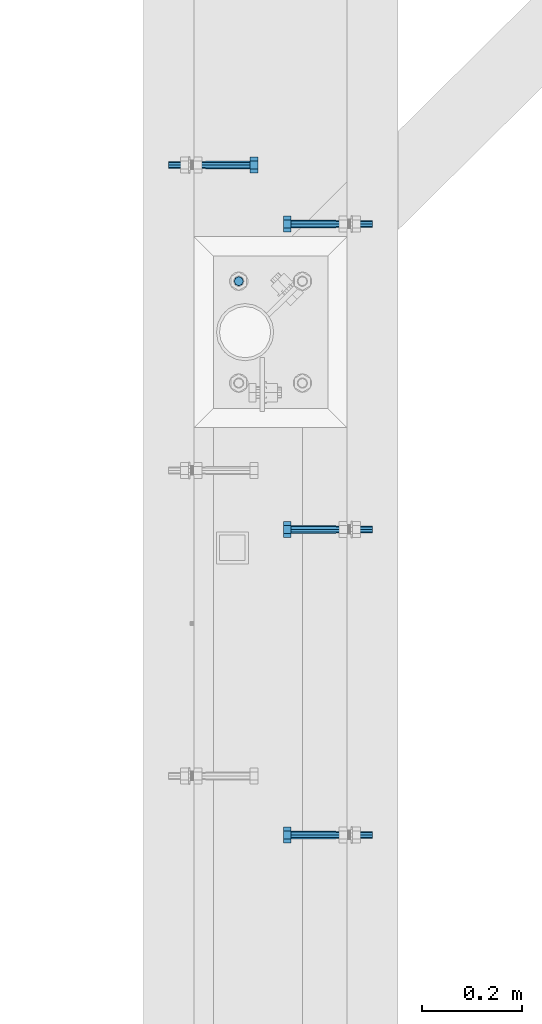
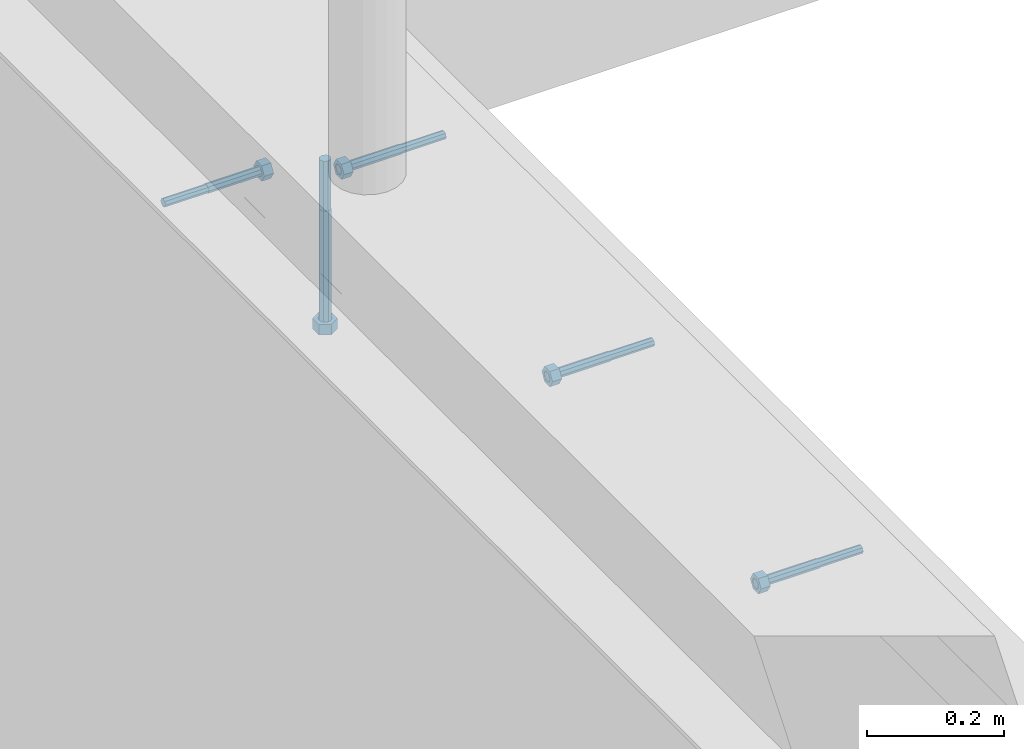
# One storey, part 418 of 975: 5 beams.
"""IFC2X3 building model written with IfcOpenShell, lengths in millimetres."""

from ifc_helpers import new_model, si_unit, frame, origin_with_axes, place, context, subcontext, project, spatial, faceted_brep, material, type_object, element, save


model = new_model("IFC2X3")

# Units and contexts
model_context = context("Model", 3, precision=1e-05, world=origin_with_axes())
body_context = subcontext(model_context, "Body", "Model", "MODEL_VIEW")
ifc_project = project(units=[si_unit("LENGTHUNIT", "METRE", prefix="MILLI"), si_unit("AREAUNIT", "SQUARE_METRE"), si_unit("VOLUMEUNIT", "CUBIC_METRE"), si_unit("MASSUNIT", "GRAM", prefix="KILO"), si_unit("TIMEUNIT", "SECOND"), si_unit("PLANEANGLEUNIT", "RADIAN"), si_unit("SOLIDANGLEUNIT", "STERADIAN"), si_unit("THERMODYNAMICTEMPERATUREUNIT", "DEGREE_CELSIUS"), si_unit("LUMINOUSINTENSITYUNIT", "LUMEN")], contexts=[model_context])

# Site, building, storey
site_placement = place(None, origin_with_axes())
site = spatial("IfcSite", under=ifc_project, at=site_placement, CompositionType="ELEMENT")
building_placement = place(site_placement, origin_with_axes())
building = spatial("IfcBuilding", under=site, at=building_placement, Name="Undefined", CompositionType="ELEMENT")
storey_placement = place(building_placement, origin_with_axes())
storey = spatial("IfcBuildingStorey", under=building, at=storey_placement, Name="Undefined", CompositionType="ELEMENT", Elevation=0.0)

# Beams
ifc_material = material(Name="STEEL/F1554-36")
beam_type_1 = type_object("IfcBeamType", PredefinedType="NOTDEFINED")
beam_1_placement = place(storey_placement, frame((2038.35003935119, 15732.1250974902, 3835.4), z_axis=(0.0, 0.0, 1.0), x_axis=(1.0, 0.0, 0.0)))
element("IfcBeam", 1, at=beam_1_placement, inside=storey, type_object=beam_type_1, material=ifc_material, Name="HEADED_ANCHOR_BOLT", context=body_context, shape_type="Brep", body=[
    faceted_brep([(88.9000000184824, 7.94000001861696, -13.7499999799138), (88.8999999527368, 15.8800000758411, 2.00943759409711e-08), (104.774999952569, 15.8800001213949, 6.97191353538074e-08), (104.775000018315, 7.94000006417082, -13.7499999302891), (88.900000064019, -7.94000009583215, -13.7499999799147), (104.775000063852, -7.9400000502792, -13.74999993029), (88.9000000438027, -15.880000153059, 2.00925569515675e-08), (104.775000043643, -15.8800001075042, 6.9716406869702e-08), (88.8999999780608, -7.94000009583488, 13.7500000200998), (104.774999977893, -7.94000005028101, 13.7500000697237), (88.8999999325279, 7.94000001861514, 13.7500000201007), (104.774999932361, 7.940000064169, 13.7500000697246), (88.9000000119959, 3.78780480527439, -7.86545778426807), (88.8999999957159, 6.82538844544797, -5.4430656647246), (88.8999999799416, 8.51112018845743, -1.94260763148395), (88.8999999677944, 8.51112018845652, 1.94260767167179), (88.8999999616899, 6.82538844544615, 5.44306570491244), (88.8999999628249, 3.78780480527257, 7.86545782445592), (88.8999999709849, -3.86089595849626e-08, 8.72999956233434), (88.8999999845473, -3.7878048824914, 7.8654578244541), (88.9000000008309, -6.82538852266407, 5.44306570491153), (88.9000000166052, -8.51112026567444, 1.94260767166998), (88.9000000287488, -8.51112026567353, -1.94260763148577), (88.9000000348606, -6.82538852266407, -5.44306566472642), (88.9000000337182, -3.78780488248958, -7.86545778426898), (88.9000000255583, -3.86080500902608e-08, -8.72999952214832), (104.775000025395, 6.94581103743985e-09, -8.72999947252447), (104.775000011829, 3.78780485082825, -7.86545773464422), (104.774999995549, 6.82538849100092, -5.44306561510075), (104.774999979774, 8.51112023401038, -1.9426075818601), (104.774999967627, 8.51112023401038, 1.94260772129564), (104.774999961523, 6.82538849100092, 5.44306575453629), (104.774999962658, 3.78780485082643, 7.86545787407977), (104.774999970818, 6.94399204803631e-09, 8.7299996119591), (104.77499998438, -3.78780483693754, 7.86545787407886), (104.775000000664, -6.82538847711112, 5.44306575453538), (104.775000016438, -8.51112022012057, 1.94260772129473), (104.775000028581, -8.51112022012057, -1.94260758186101), (104.775000034693, -6.82538847711021, -5.44306561510166), (104.775000033551, -3.78780483693663, -7.86545773464422), (-2.99107341561466e-07, -5.61266007567065, 5.61266007566792), (-4.22995071858168e-07, -7.93750000000728, 0.0), (104.774999998088, -7.93749999999, -4.45652403868735e-11), (104.774999998088, -5.61266007565791, 5.61266007562426), (-1.09139364212751e-11, 1.81898940354586e-12, 7.9375), (104.774999998095, 1.18234311230481e-11, 7.93749999995816), (2.99089151667431e-07, 5.61266007567428, 5.61266007566792), (104.774999998102, 5.61266007568065, 5.61266007562517), (4.22980519942939e-07, 7.93750000001091, 0.0), (104.77499999811, 7.93750000001364, -4.36557456851006e-11), (2.99089151667431e-07, 5.61266007567428, -5.61266007566792), (104.774999998102, 5.61266007568156, -5.61266007571339), (-1.09139364212751e-11, 1.81898940354586e-12, -7.9375), (104.774999998099, 1.2732925824821e-11, -7.93750000004547), (-73.0249999592124, 5.05157065939329, -5.0515715445581), (-73.0249999269472, -1.85405951924622e-07, -7.14400069976364), (-73.0249999328516, -5.0515710302052, -5.05157154455992), (-73.0249999734697, -7.14400018541073, -6.9975976657588e-07), (-73.0250000250016, -5.05157103020611, 5.05157014504039), (-73.0250000572705, -1.85406861419324e-07, 7.1439993002441), (-73.0250000513661, 5.05157065939238, 5.05157014503948), (-73.025000010748, 7.14399981459792, -6.99758857081179e-07), (0.00625003290042514, 5.05157085007795, -5.05157087849238), (0.00625006516929716, 5.27870724909008e-09, -7.1440000336961), (0.00625005926485755, -5.05157083952145, -5.05157087849329), (0.00625001864682417, -7.14399999472516, -3.36940502165817e-08), (0.00624996711121639, -5.05157083952145, 5.05157081110519), (0.00624993484598235, 5.2777977543883e-09, 7.14399996631164), (0.00624994074678398, 5.05157085007704, 5.05157081110701), (0.00624998136845534, 7.14400000528167, -3.36922312271781e-08), (-2.99107341561466e-07, -5.61266007567065, -5.61266007566792), (104.774999998092, -5.612660075657, -5.6126600757143)], [[[0, 1, 2, 3]], [[4, 0, 3, 5]], [[6, 4, 5, 7]], [[8, 6, 7, 9]], [[10, 8, 9, 11]], [[0, 4, 6, 8, 10, 1], [12, 13, 14, 15, 16, 17, 18, 19, 20, 21, 22, 23, 24, 25]], [[12, 25, 26, 27]], [[13, 12, 27, 28]], [[14, 13, 28, 29]], [[15, 14, 29, 30]], [[16, 15, 30, 31]], [[17, 16, 31, 32]], [[18, 17, 32, 33]], [[19, 18, 33, 34]], [[20, 19, 34, 35]], [[21, 20, 35, 36]], [[22, 21, 36, 37]], [[23, 22, 37, 38]], [[24, 23, 38, 39]], [[25, 24, 39, 26]], [[9, 7, 5, 3, 2, 11], [38, 37, 36, 35, 34, 33, 32, 31, 30, 29, 28, 27, 26, 39]], [[1, 10, 11, 2]], [[40, 41, 42, 43]], [[44, 40, 43, 45]], [[46, 44, 45, 47]], [[48, 46, 47, 49]], [[50, 48, 49, 51]], [[52, 50, 51, 53]], [[54, 55, 56, 57, 58, 59, 60, 61]], [[55, 54, 62, 63]], [[56, 55, 63, 64]], [[57, 56, 64, 65]], [[58, 57, 65, 66]], [[59, 58, 66, 67]], [[60, 59, 67, 68]], [[61, 60, 68, 69]], [[54, 61, 69, 62]], [[40, 44, 46, 48, 50, 52, 70, 41], [68, 67, 66, 65, 64, 63, 62, 69]], [[41, 70, 71, 42]], [[53, 51, 49, 47, 45, 43, 42, 71]], [[70, 52, 53, 71]]]),
])
beam_2_placement = place(storey_placement, frame((2298.70013689956, 15614.6499761124, 3886.2), z_axis=(0.0, 0.0, 1.0), x_axis=(-0.999999999999998, 6.90000001668524e-08, 0.0)))
element("IfcBeam", 2, at=beam_2_placement, inside=storey, type_object=beam_type_1, material=ifc_material, Name="HEADED_ANCHOR_BOLT", context=body_context, shape_type="Brep", body=[
    faceted_brep([(88.9000000184824, 7.94000001861696, -13.7499999799138), (88.8999999527368, 15.8800000758411, 2.00943759409711e-08), (104.774999952569, 15.8800001213949, 6.97191353538074e-08), (104.775000018315, 7.94000006417082, -13.7499999302891), (88.900000064019, -7.94000009583215, -13.7499999799147), (104.775000063852, -7.9400000502792, -13.74999993029), (88.9000000438027, -15.880000153059, 2.00925569515675e-08), (104.775000043643, -15.8800001075042, 6.9716406869702e-08), (88.8999999780608, -7.94000009583488, 13.7500000200998), (104.774999977893, -7.94000005028101, 13.7500000697237), (88.8999999325279, 7.94000001861514, 13.7500000201007), (104.774999932361, 7.940000064169, 13.7500000697246), (88.9000000119959, 3.78780480527439, -7.86545778426807), (88.8999999957159, 6.82538844544797, -5.4430656647246), (88.8999999799416, 8.51112018845743, -1.94260763148395), (88.8999999677944, 8.51112018845652, 1.94260767167179), (88.8999999616899, 6.82538844544615, 5.44306570491244), (88.8999999628249, 3.78780480527257, 7.86545782445592), (88.8999999709849, -3.86089595849626e-08, 8.72999956233434), (88.8999999845473, -3.7878048824914, 7.8654578244541), (88.9000000008309, -6.82538852266407, 5.44306570491153), (88.9000000166052, -8.51112026567444, 1.94260767166998), (88.9000000287488, -8.51112026567353, -1.94260763148577), (88.9000000348606, -6.82538852266407, -5.44306566472642), (88.9000000337182, -3.78780488248958, -7.86545778426898), (88.9000000255583, -3.86080500902608e-08, -8.72999952214832), (104.775000025395, 6.94581103743985e-09, -8.72999947252447), (104.775000011829, 3.78780485082825, -7.86545773464422), (104.774999995549, 6.82538849100092, -5.44306561510075), (104.774999979774, 8.51112023401038, -1.9426075818601), (104.774999967627, 8.51112023401038, 1.94260772129564), (104.774999961523, 6.82538849100092, 5.44306575453629), (104.774999962658, 3.78780485082643, 7.86545787407977), (104.774999970818, 6.94399204803631e-09, 8.7299996119591), (104.77499998438, -3.78780483693754, 7.86545787407886), (104.775000000664, -6.82538847711112, 5.44306575453538), (104.775000016438, -8.51112022012057, 1.94260772129473), (104.775000028581, -8.51112022012057, -1.94260758186101), (104.775000034693, -6.82538847711021, -5.44306561510166), (104.775000033551, -3.78780483693663, -7.86545773464422), (-2.99107341561466e-07, -5.61266007567065, 5.61266007566792), (-4.22995071858168e-07, -7.93750000000728, 0.0), (104.774999998088, -7.93749999999, -4.45652403868735e-11), (104.774999998088, -5.61266007565791, 5.61266007562426), (-1.09139364212751e-11, 1.81898940354586e-12, 7.9375), (104.774999998095, 1.18234311230481e-11, 7.93749999995816), (2.99089151667431e-07, 5.61266007567428, 5.61266007566792), (104.774999998102, 5.61266007568065, 5.61266007562517), (4.22980519942939e-07, 7.93750000001091, 0.0), (104.77499999811, 7.93750000001364, -4.36557456851006e-11), (2.99089151667431e-07, 5.61266007567428, -5.61266007566792), (104.774999998102, 5.61266007568156, -5.61266007571339), (-1.09139364212751e-11, 1.81898940354586e-12, -7.9375), (104.774999998099, 1.2732925824821e-11, -7.93750000004547), (-73.0249999592124, 5.05157065939329, -5.0515715445581), (-73.0249999269472, -1.85405951924622e-07, -7.14400069976364), (-73.0249999328516, -5.0515710302052, -5.05157154455992), (-73.0249999734697, -7.14400018541073, -6.9975976657588e-07), (-73.0250000250016, -5.05157103020611, 5.05157014504039), (-73.0250000572705, -1.85406861419324e-07, 7.1439993002441), (-73.0250000513661, 5.05157065939238, 5.05157014503948), (-73.025000010748, 7.14399981459792, -6.99758857081179e-07), (0.00625003290042514, 5.05157085007795, -5.05157087849238), (0.00625006516929716, 5.27870724909008e-09, -7.1440000336961), (0.00625005926485755, -5.05157083952145, -5.05157087849329), (0.00625001864682417, -7.14399999472516, -3.36940502165817e-08), (0.00624996711121639, -5.05157083952145, 5.05157081110519), (0.00624993484598235, 5.2777977543883e-09, 7.14399996631164), (0.00624994074678398, 5.05157085007704, 5.05157081110701), (0.00624998136845534, 7.14400000528167, -3.36922312271781e-08), (-2.99107341561466e-07, -5.61266007567065, -5.61266007566792), (104.774999998092, -5.612660075657, -5.6126600757143)], [[[0, 1, 2, 3]], [[4, 0, 3, 5]], [[6, 4, 5, 7]], [[8, 6, 7, 9]], [[10, 8, 9, 11]], [[0, 4, 6, 8, 10, 1], [12, 13, 14, 15, 16, 17, 18, 19, 20, 21, 22, 23, 24, 25]], [[12, 25, 26, 27]], [[13, 12, 27, 28]], [[14, 13, 28, 29]], [[15, 14, 29, 30]], [[16, 15, 30, 31]], [[17, 16, 31, 32]], [[18, 17, 32, 33]], [[19, 18, 33, 34]], [[20, 19, 34, 35]], [[21, 20, 35, 36]], [[22, 21, 36, 37]], [[23, 22, 37, 38]], [[24, 23, 38, 39]], [[25, 24, 39, 26]], [[9, 7, 5, 3, 2, 11], [38, 37, 36, 35, 34, 33, 32, 31, 30, 29, 28, 27, 26, 39]], [[1, 10, 11, 2]], [[40, 41, 42, 43]], [[44, 40, 43, 45]], [[46, 44, 45, 47]], [[48, 46, 47, 49]], [[50, 48, 49, 51]], [[52, 50, 51, 53]], [[54, 55, 56, 57, 58, 59, 60, 61]], [[55, 54, 62, 63]], [[56, 55, 63, 64]], [[57, 56, 64, 65]], [[58, 57, 65, 66]], [[59, 58, 66, 67]], [[60, 59, 67, 68]], [[61, 60, 68, 69]], [[54, 61, 69, 62]], [[40, 44, 46, 48, 50, 52, 70, 41], [68, 67, 66, 65, 64, 63, 62, 69]], [[41, 70, 71, 42]], [[53, 51, 49, 47, 45, 43, 42, 71]], [[70, 52, 53, 71]]]),
])
beam_3_placement = place(storey_placement, frame((2298.70010093317, 15005.0499761124, 3886.2), z_axis=(0.0, 0.0, 1.0), x_axis=(-0.999999999999998, 6.90000001668524e-08, 0.0)))
element("IfcBeam", 3, at=beam_3_placement, inside=storey, type_object=beam_type_1, material=ifc_material, Name="HEADED_ANCHOR_BOLT", context=body_context, shape_type="Brep", body=[
    faceted_brep([(88.9000000184824, 7.94000001861696, -13.7499999799138), (88.8999999527368, 15.8800000758411, 2.00943759409711e-08), (104.774999952569, 15.8800001213949, 6.97191353538074e-08), (104.775000018315, 7.94000006417082, -13.7499999302891), (88.900000064019, -7.94000009583215, -13.7499999799147), (104.775000063852, -7.9400000502792, -13.74999993029), (88.9000000438027, -15.880000153059, 2.00925569515675e-08), (104.775000043643, -15.8800001075042, 6.9716406869702e-08), (88.8999999780608, -7.94000009583488, 13.7500000200998), (104.774999977893, -7.94000005028101, 13.7500000697237), (88.8999999325279, 7.94000001861514, 13.7500000201007), (104.774999932361, 7.940000064169, 13.7500000697246), (88.9000000119959, 3.78780480527439, -7.86545778426807), (88.8999999957159, 6.82538844544797, -5.4430656647246), (88.8999999799416, 8.51112018845743, -1.94260763148395), (88.8999999677944, 8.51112018845652, 1.94260767167179), (88.8999999616899, 6.82538844544615, 5.44306570491244), (88.8999999628249, 3.78780480527257, 7.86545782445592), (88.8999999709849, -3.86089595849626e-08, 8.72999956233434), (88.8999999845473, -3.7878048824914, 7.8654578244541), (88.9000000008309, -6.82538852266407, 5.44306570491153), (88.9000000166052, -8.51112026567444, 1.94260767166998), (88.9000000287488, -8.51112026567353, -1.94260763148577), (88.9000000348606, -6.82538852266407, -5.44306566472642), (88.9000000337182, -3.78780488248958, -7.86545778426898), (88.9000000255583, -3.86080500902608e-08, -8.72999952214832), (104.775000025395, 6.94581103743985e-09, -8.72999947252447), (104.775000011829, 3.78780485082825, -7.86545773464422), (104.774999995549, 6.82538849100092, -5.44306561510075), (104.774999979774, 8.51112023401038, -1.9426075818601), (104.774999967627, 8.51112023401038, 1.94260772129564), (104.774999961523, 6.82538849100092, 5.44306575453629), (104.774999962658, 3.78780485082643, 7.86545787407977), (104.774999970818, 6.94399204803631e-09, 8.7299996119591), (104.77499998438, -3.78780483693754, 7.86545787407886), (104.775000000664, -6.82538847711112, 5.44306575453538), (104.775000016438, -8.51112022012057, 1.94260772129473), (104.775000028581, -8.51112022012057, -1.94260758186101), (104.775000034693, -6.82538847711021, -5.44306561510166), (104.775000033551, -3.78780483693663, -7.86545773464422), (-2.99107341561466e-07, -5.61266007567065, 5.61266007566792), (-4.22995071858168e-07, -7.93750000000728, 0.0), (104.774999998088, -7.93749999999, -4.45652403868735e-11), (104.774999998088, -5.61266007565791, 5.61266007562426), (-1.09139364212751e-11, 1.81898940354586e-12, 7.9375), (104.774999998095, 1.18234311230481e-11, 7.93749999995816), (2.99089151667431e-07, 5.61266007567428, 5.61266007566792), (104.774999998102, 5.61266007568065, 5.61266007562517), (4.22980519942939e-07, 7.93750000001091, 0.0), (104.77499999811, 7.93750000001364, -4.36557456851006e-11), (2.99089151667431e-07, 5.61266007567428, -5.61266007566792), (104.774999998102, 5.61266007568156, -5.61266007571339), (-1.09139364212751e-11, 1.81898940354586e-12, -7.9375), (104.774999998099, 1.2732925824821e-11, -7.93750000004547), (-73.0249999592124, 5.05157065939329, -5.0515715445581), (-73.0249999269472, -1.85405951924622e-07, -7.14400069976364), (-73.0249999328516, -5.0515710302052, -5.05157154455992), (-73.0249999734697, -7.14400018541073, -6.9975976657588e-07), (-73.0250000250016, -5.05157103020611, 5.05157014504039), (-73.0250000572705, -1.85406861419324e-07, 7.1439993002441), (-73.0250000513661, 5.05157065939238, 5.05157014503948), (-73.025000010748, 7.14399981459792, -6.99758857081179e-07), (0.00625003290042514, 5.05157085007795, -5.05157087849238), (0.00625006516929716, 5.27870724909008e-09, -7.1440000336961), (0.00625005926485755, -5.05157083952145, -5.05157087849329), (0.00625001864682417, -7.14399999472516, -3.36940502165817e-08), (0.00624996711121639, -5.05157083952145, 5.05157081110519), (0.00624993484598235, 5.2777977543883e-09, 7.14399996631164), (0.00624994074678398, 5.05157085007704, 5.05157081110701), (0.00624998136845534, 7.14400000528167, -3.36922312271781e-08), (-2.99107341561466e-07, -5.61266007567065, -5.61266007566792), (104.774999998092, -5.612660075657, -5.6126600757143)], [[[0, 1, 2, 3]], [[4, 0, 3, 5]], [[6, 4, 5, 7]], [[8, 6, 7, 9]], [[10, 8, 9, 11]], [[0, 4, 6, 8, 10, 1], [12, 13, 14, 15, 16, 17, 18, 19, 20, 21, 22, 23, 24, 25]], [[12, 25, 26, 27]], [[13, 12, 27, 28]], [[14, 13, 28, 29]], [[15, 14, 29, 30]], [[16, 15, 30, 31]], [[17, 16, 31, 32]], [[18, 17, 32, 33]], [[19, 18, 33, 34]], [[20, 19, 34, 35]], [[21, 20, 35, 36]], [[22, 21, 36, 37]], [[23, 22, 37, 38]], [[24, 23, 38, 39]], [[25, 24, 39, 26]], [[9, 7, 5, 3, 2, 11], [38, 37, 36, 35, 34, 33, 32, 31, 30, 29, 28, 27, 26, 39]], [[1, 10, 11, 2]], [[40, 41, 42, 43]], [[44, 40, 43, 45]], [[46, 44, 45, 47]], [[48, 46, 47, 49]], [[50, 48, 49, 51]], [[52, 50, 51, 53]], [[54, 55, 56, 57, 58, 59, 60, 61]], [[55, 54, 62, 63]], [[56, 55, 63, 64]], [[57, 56, 64, 65]], [[58, 57, 65, 66]], [[59, 58, 66, 67]], [[60, 59, 67, 68]], [[61, 60, 68, 69]], [[54, 61, 69, 62]], [[40, 44, 46, 48, 50, 52, 70, 41], [68, 67, 66, 65, 64, 63, 62, 69]], [[41, 70, 71, 42]], [[53, 51, 49, 47, 45, 43, 42, 71]], [[70, 52, 53, 71]]]),
])
beam_4_placement = place(storey_placement, frame((2298.70006496676, 14395.4499761124, 3886.2), z_axis=(0.0, 0.0, 1.0), x_axis=(-0.999999999999998, 6.90000001668524e-08, 0.0)))
element("IfcBeam", 4, at=beam_4_placement, inside=storey, type_object=beam_type_1, material=ifc_material, Name="HEADED_ANCHOR_BOLT", context=body_context, shape_type="Brep", body=[
    faceted_brep([(88.9000000184824, 7.94000001861696, -13.7499999799138), (88.8999999527368, 15.8800000758411, 2.00943759409711e-08), (104.774999952569, 15.8800001213949, 6.97191353538074e-08), (104.775000018315, 7.94000006417082, -13.7499999302891), (88.900000064019, -7.94000009583215, -13.7499999799147), (104.775000063852, -7.9400000502792, -13.74999993029), (88.9000000438027, -15.880000153059, 2.00925569515675e-08), (104.775000043643, -15.8800001075042, 6.9716406869702e-08), (88.8999999780608, -7.94000009583488, 13.7500000200998), (104.774999977893, -7.94000005028101, 13.7500000697237), (88.8999999325279, 7.94000001861514, 13.7500000201007), (104.774999932361, 7.940000064169, 13.7500000697246), (88.9000000119959, 3.78780480527439, -7.86545778426807), (88.8999999957159, 6.82538844544797, -5.4430656647246), (88.8999999799416, 8.51112018845743, -1.94260763148395), (88.8999999677944, 8.51112018845652, 1.94260767167179), (88.8999999616899, 6.82538844544615, 5.44306570491244), (88.8999999628249, 3.78780480527257, 7.86545782445592), (88.8999999709849, -3.86089595849626e-08, 8.72999956233434), (88.8999999845473, -3.7878048824914, 7.8654578244541), (88.9000000008309, -6.82538852266407, 5.44306570491153), (88.9000000166052, -8.51112026567444, 1.94260767166998), (88.9000000287488, -8.51112026567353, -1.94260763148577), (88.9000000348606, -6.82538852266407, -5.44306566472642), (88.9000000337182, -3.78780488248958, -7.86545778426898), (88.9000000255583, -3.86080500902608e-08, -8.72999952214832), (104.775000025395, 6.94581103743985e-09, -8.72999947252447), (104.775000011829, 3.78780485082825, -7.86545773464422), (104.774999995549, 6.82538849100092, -5.44306561510075), (104.774999979774, 8.51112023401038, -1.9426075818601), (104.774999967627, 8.51112023401038, 1.94260772129564), (104.774999961523, 6.82538849100092, 5.44306575453629), (104.774999962658, 3.78780485082643, 7.86545787407977), (104.774999970818, 6.94399204803631e-09, 8.7299996119591), (104.77499998438, -3.78780483693754, 7.86545787407886), (104.775000000664, -6.82538847711112, 5.44306575453538), (104.775000016438, -8.51112022012057, 1.94260772129473), (104.775000028581, -8.51112022012057, -1.94260758186101), (104.775000034693, -6.82538847711021, -5.44306561510166), (104.775000033551, -3.78780483693663, -7.86545773464422), (-2.99107341561466e-07, -5.61266007567065, 5.61266007566792), (-4.22995071858168e-07, -7.93750000000728, 0.0), (104.774999998088, -7.93749999999, -4.45652403868735e-11), (104.774999998088, -5.61266007565791, 5.61266007562426), (-1.09139364212751e-11, 1.81898940354586e-12, 7.9375), (104.774999998095, 1.18234311230481e-11, 7.93749999995816), (2.99089151667431e-07, 5.61266007567428, 5.61266007566792), (104.774999998102, 5.61266007568065, 5.61266007562517), (4.22980519942939e-07, 7.93750000001091, 0.0), (104.77499999811, 7.93750000001364, -4.36557456851006e-11), (2.99089151667431e-07, 5.61266007567428, -5.61266007566792), (104.774999998102, 5.61266007568156, -5.61266007571339), (-1.09139364212751e-11, 1.81898940354586e-12, -7.9375), (104.774999998099, 1.2732925824821e-11, -7.93750000004547), (-73.0249999592124, 5.05157065939329, -5.0515715445581), (-73.0249999269472, -1.85405951924622e-07, -7.14400069976364), (-73.0249999328516, -5.0515710302052, -5.05157154455992), (-73.0249999734697, -7.14400018541073, -6.9975976657588e-07), (-73.0250000250016, -5.05157103020611, 5.05157014504039), (-73.0250000572705, -1.85406861419324e-07, 7.1439993002441), (-73.0250000513661, 5.05157065939238, 5.05157014503948), (-73.025000010748, 7.14399981459792, -6.99758857081179e-07), (0.00625003290042514, 5.05157085007795, -5.05157087849238), (0.00625006516929716, 5.27870724909008e-09, -7.1440000336961), (0.00625005926485755, -5.05157083952145, -5.05157087849329), (0.00625001864682417, -7.14399999472516, -3.36940502165817e-08), (0.00624996711121639, -5.05157083952145, 5.05157081110519), (0.00624993484598235, 5.2777977543883e-09, 7.14399996631164), (0.00624994074678398, 5.05157085007704, 5.05157081110701), (0.00624998136845534, 7.14400000528167, -3.36922312271781e-08), (-2.99107341561466e-07, -5.61266007567065, -5.61266007566792), (104.774999998092, -5.612660075657, -5.6126600757143)], [[[0, 1, 2, 3]], [[4, 0, 3, 5]], [[6, 4, 5, 7]], [[8, 6, 7, 9]], [[10, 8, 9, 11]], [[0, 4, 6, 8, 10, 1], [12, 13, 14, 15, 16, 17, 18, 19, 20, 21, 22, 23, 24, 25]], [[12, 25, 26, 27]], [[13, 12, 27, 28]], [[14, 13, 28, 29]], [[15, 14, 29, 30]], [[16, 15, 30, 31]], [[17, 16, 31, 32]], [[18, 17, 32, 33]], [[19, 18, 33, 34]], [[20, 19, 34, 35]], [[21, 20, 35, 36]], [[22, 21, 36, 37]], [[23, 22, 37, 38]], [[24, 23, 38, 39]], [[25, 24, 39, 26]], [[9, 7, 5, 3, 2, 11], [38, 37, 36, 35, 34, 33, 32, 31, 30, 29, 28, 27, 26, 39]], [[1, 10, 11, 2]], [[40, 41, 42, 43]], [[44, 40, 43, 45]], [[46, 44, 45, 47]], [[48, 46, 47, 49]], [[50, 48, 49, 51]], [[52, 50, 51, 53]], [[54, 55, 56, 57, 58, 59, 60, 61]], [[55, 54, 62, 63]], [[56, 55, 63, 64]], [[57, 56, 64, 65]], [[58, 57, 65, 66]], [[59, 58, 66, 67]], [[60, 59, 67, 68]], [[61, 60, 68, 69]], [[54, 61, 69, 62]], [[40, 44, 46, 48, 50, 52, 70, 41], [68, 67, 66, 65, 64, 63, 62, 69]], [[41, 70, 71, 42]], [[53, 51, 49, 47, 45, 43, 42, 71]], [[70, 52, 53, 71]]]),
])
beam_type_2 = type_object("IfcBeamType", PredefinedType="NOTDEFINED")
beam_5_placement = place(storey_placement, frame((2105.02500137408, 15500.3500011752, 3917.95), z_axis=(1.0, 0.0, 0.0), x_axis=(0.0, 0.0, -1.0)))
element("IfcBeam", 5, at=beam_5_placement, inside=storey, type_object=beam_type_2, material=ifc_material, Name="HEADED_BOLT", context=body_context, shape_type="Brep", body=[
    faceted_brep([(196.84375, -9.12999965559902, 15.8099993757314), (196.84375, -18.2599997700399, -1.0438852768857e-06), (215.893749999999, -18.2599997700399, -1.0438852768857e-06), (215.893749999999, -9.12999965559902, 15.8099993757314), (196.84375, 9.13000057328281, 15.8099993757314), (215.893749999999, 9.13000057328281, 15.8099993757314), (196.84375, 18.2600006877237, -1.0438852768857e-06), (215.893749999999, 18.2600006877237, -1.0438852768857e-06), (196.84375, 9.13000057328281, -15.810001463502), (215.893749999999, 9.13000057328281, -15.810001463502), (196.84375, -9.12999965559902, -15.810001463502), (215.893749999999, -9.12999965559902, -15.810001463502), (196.84375, -4.47767959644079, 9.2979973979138), (196.84375, -8.06850020163256, 6.43441352102286), (196.84375, -10.0612552973498, 2.29641492663589), (196.84375, -10.0612552973498, -2.29641701440644), (196.84375, -8.06850020163256, -6.43441560879344), (196.84375, -4.47767959644079, -9.29799948568439), (196.84375, 4.58841896033846e-07, -10.3200007387095), (196.84375, 4.47768051412459, -9.29799948568436), (196.84375, 8.06850111931635, -6.43441560879342), (196.84375, 10.0612562150336, -2.29641701440644), (196.84375, 10.0612562150336, 2.29641492663589), (196.84375, 8.06850111931635, 6.43441352102289), (196.84375, 4.47768051412459, 9.29799739791383), (196.84375, 4.58841896033846e-07, 10.3199986509389), (215.893749999999, 4.58841896033846e-07, 10.3199986509389), (215.893749999999, -4.47767959644079, 9.2979973979138), (215.893749999999, -8.06850020163256, 6.43441352102286), (215.893749999999, -10.0612552973498, 2.29641492663589), (215.893749999999, -10.0612552973498, -2.29641701440644), (215.893749999999, -8.06850020163256, -6.43441560879344), (215.893749999999, -4.47767959644079, -9.29799948568439), (215.893749999999, 4.58841896033846e-07, -10.3200007387095), (215.893749999999, 4.47768051412459, -9.29799948568436), (215.893749999999, 8.06850111931635, -6.43441560879342), (215.893749999999, 10.0612562150336, -2.29641701440644), (215.893749999999, 10.0612562150336, 2.29641492663589), (215.893749999999, 8.06850111931635, 6.43441352102289), (215.893749999999, 4.47768051412459, 9.29799739791383), (0.0, -6.73519209080223, 6.73519209080186), (0.0, -9.52499999999964, 0.0), (215.900000000001, -9.52499999999964, 0.0), (215.900000000001, -6.73519209080223, 6.73519209080186), (-9.87109982941227e-13, -1.20792265079217e-13, 9.52499961853027), (215.900000000001, 0.0, 9.52500000000001), (0.0, 6.73519209080223, 6.73519209080186), (215.900000000001, 6.73519209080223, 6.73519209080186), (0.0, 9.52499999999964, 0.0), (215.900000000001, 9.52499999999964, 0.0), (0.0, 6.73519209080223, -6.73519209080186), (215.900000000001, 6.73519209080223, -6.73519209080186), (2.95075507493764e-12, -1.20792265079217e-13, -9.52499961853027), (215.900000000001, 0.0, -9.52500000000001), (-88.9444446471748, -6.3639605718372, 6.39952908988423), (-88.9433906823501, 4.58841896033846e-07, 9.03556784850662), (-88.9444446471748, 6.36396148952099, 6.39952908988423), (-88.9469891433491, 9.0000004588419, 0.0355685678769078), (-88.9495336395235, 6.36396148952099, -6.32839195413041), (-88.9505876043481, 4.58841896033846e-07, -8.9644307127528), (-88.9495336395235, -6.3639605718372, -6.32839195413041), (-88.9469891433491, -8.9999995411581, 0.0355685678769078), (0.0124298302243915, 6.36396148952099, -6.36396152997716), (0.0113758653997138, 4.58841896033846e-07, -9.00000028859955), (0.0124298302243915, -6.3639605718372, -6.36396152997716), (0.0149743263987148, -8.9999995411581, -1.00796984270346e-06), (0.0175188225730381, -6.3639605718372, 6.36395951403748), (0.0185727873977157, 4.58841896033846e-07, 8.99999827265987), (0.0175188225730381, 6.36396148952099, 6.36395951403748), (0.0149743263987148, 9.0000004588419, -1.00796984270346e-06), (0.0, -6.73519209080223, -6.73519209080186), (215.900000000001, -6.73519209080223, -6.73519209080186)], [[[0, 1, 2, 3]], [[4, 0, 3, 5]], [[6, 4, 5, 7]], [[8, 6, 7, 9]], [[10, 8, 9, 11]], [[0, 4, 6, 8, 10, 1], [12, 13, 14, 15, 16, 17, 18, 19, 20, 21, 22, 23, 24, 25]], [[12, 25, 26, 27]], [[13, 12, 27, 28]], [[14, 13, 28, 29]], [[15, 14, 29, 30]], [[16, 15, 30, 31]], [[17, 16, 31, 32]], [[18, 17, 32, 33]], [[19, 18, 33, 34]], [[20, 19, 34, 35]], [[21, 20, 35, 36]], [[22, 21, 36, 37]], [[23, 22, 37, 38]], [[24, 23, 38, 39]], [[25, 24, 39, 26]], [[9, 7, 5, 3, 2, 11], [38, 37, 36, 35, 34, 33, 32, 31, 30, 29, 28, 27, 26, 39]], [[1, 10, 11, 2]], [[40, 41, 42, 43]], [[44, 40, 43, 45]], [[46, 44, 45, 47]], [[48, 46, 47, 49]], [[50, 48, 49, 51]], [[52, 50, 51, 53]], [[54, 55, 56, 57, 58, 59, 60, 61]], [[59, 58, 62, 63]], [[60, 59, 63, 64]], [[61, 60, 64, 65]], [[54, 61, 65, 66]], [[55, 54, 66, 67]], [[56, 55, 67, 68]], [[57, 56, 68, 69]], [[58, 57, 69, 62]], [[40, 44, 46, 48, 50, 52, 70, 41], [68, 67, 66, 65, 64, 63, 62, 69]], [[41, 70, 71, 42]], [[53, 51, 49, 47, 45, 43, 42, 71]], [[70, 52, 53, 71]]]),
])

save(model, "model.ifc")
